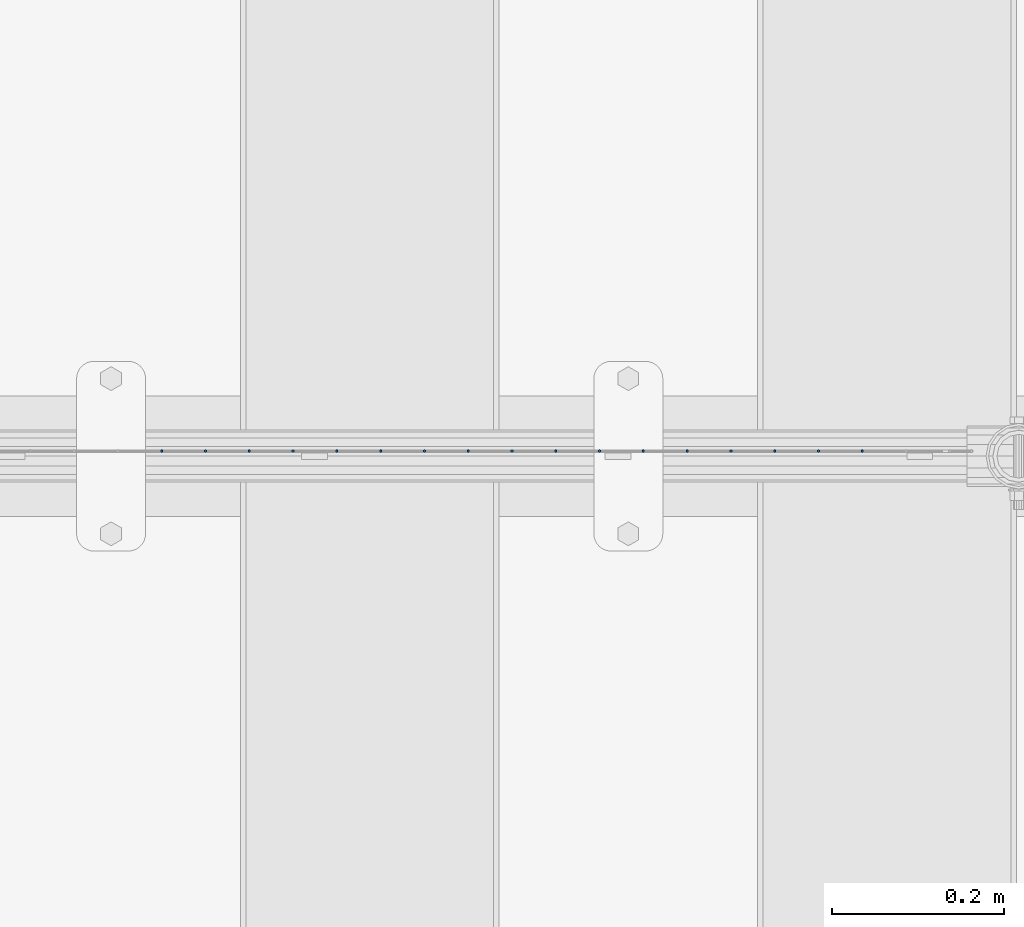
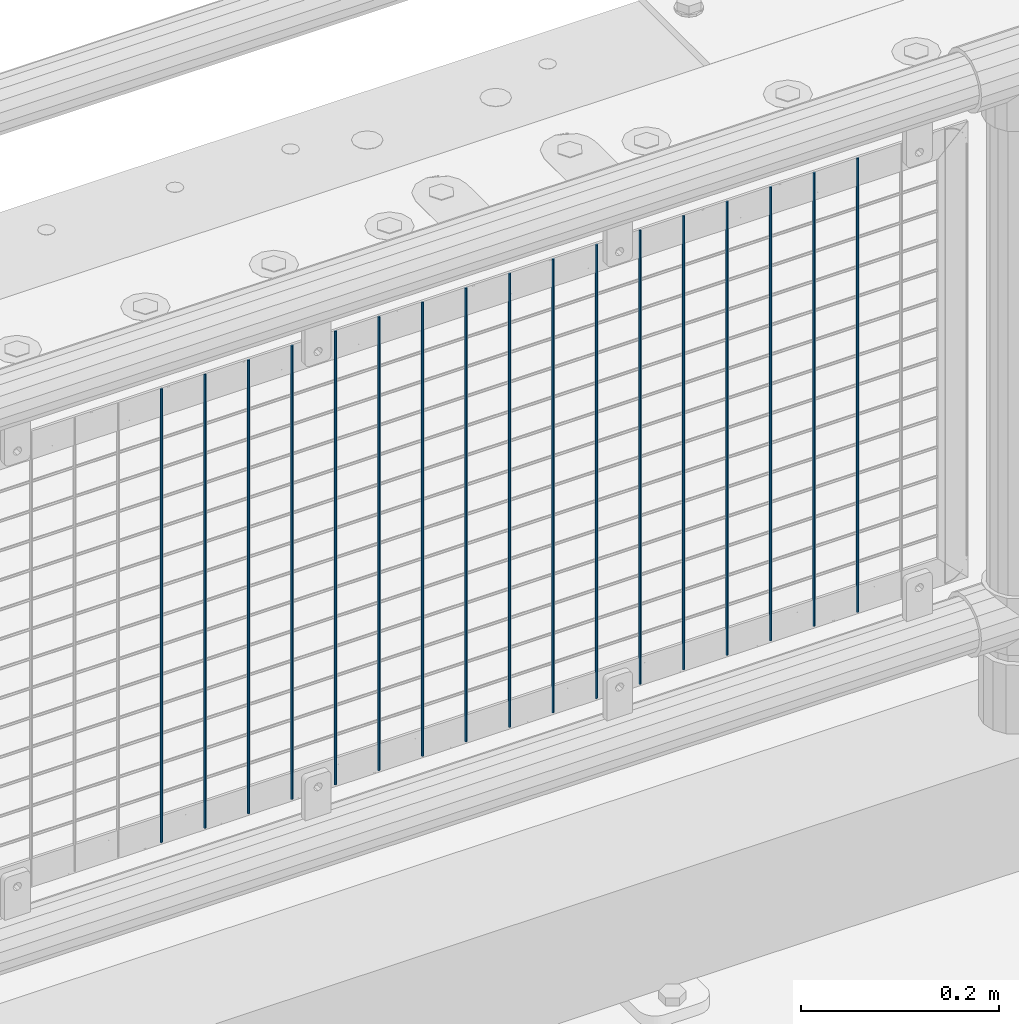
# One storey, part 74 of 242: 17 columns.
"""IFC2X3 building model written with IfcOpenShell, lengths in millimetres."""

from ifc_helpers import new_model, si_unit, frame, origin_with_axes, place, context, subcontext, project, spatial, faceted_brep, material, type_object, element, save


model = new_model("IFC2X3")

# Units and contexts
model_context = context("Model", 3, precision=1e-05, world=origin_with_axes())
body_context = subcontext(model_context, "Body", "Model", "MODEL_VIEW")
ifc_project = project(units=[si_unit("LENGTHUNIT", "METRE", prefix="MILLI"), si_unit("AREAUNIT", "SQUARE_METRE"), si_unit("VOLUMEUNIT", "CUBIC_METRE"), si_unit("MASSUNIT", "GRAM", prefix="KILO"), si_unit("TIMEUNIT", "SECOND"), si_unit("PLANEANGLEUNIT", "RADIAN"), si_unit("SOLIDANGLEUNIT", "STERADIAN"), si_unit("THERMODYNAMICTEMPERATUREUNIT", "DEGREE_CELSIUS"), si_unit("LUMINOUSINTENSITYUNIT", "LUMEN")], contexts=[model_context])

# Site, building, storey
site_placement = place(None, origin_with_axes())
site = spatial("IfcSite", under=ifc_project, at=site_placement, CompositionType="ELEMENT")
building_placement = place(site_placement, origin_with_axes())
building = spatial("IfcBuilding", under=site, at=building_placement, Name="Standard", CompositionType="ELEMENT")
storey_placement = place(building_placement, origin_with_axes())
storey = spatial("IfcBuildingStorey", under=building, at=storey_placement, Name="Undefined", CompositionType="ELEMENT", Elevation=0.0)

# Columns
ifc_material = material(Name="Misc_Undefined")
column_type = type_object("IfcColumnType", Name="D3", PredefinedType="NOTDEFINED")
for number, where, z_axis, x_axis in (
    (1, (-35478.589, -19329.5, 353.02), (-1.0, 0.0, 0.0), (0.0, 0.0, 1.0)),
    (2, (-35529.382, -19329.5, 353.02), (-1.0, 0.0, 0.0), (0.0, 0.0, 1.0)),
    (3, (-35580.175, -19329.5, 353.02), (-1.0, 0.0, 0.0), (0.0, 0.0, 1.0)),
    (4, (-35630.968, -19329.5, 353.02), (-1.0, 0.0, 0.0), (0.0, 0.0, 1.0)),
    (5, (-35681.761, -19329.5, 353.02), (-1.0, 0.0, 0.0), (0.0, 0.0, 1.0)),
    (6, (-35732.554, -19329.5, 353.02), (-1.0, 0.0, 0.0), (0.0, 0.0, 1.0)),
    (7, (-35783.347, -19329.5, 353.02), (-1.0, 0.0, 0.0), (0.0, 0.0, 1.0)),
    (8, (-35834.14, -19329.5, 353.02), (-1.0, 0.0, 0.0), (0.0, 0.0, 1.0)),
    (9, (-35884.933, -19329.5, 353.02), (-1.0, 0.0, 0.0), (0.0, 0.0, 1.0)),
    (10, (-35935.726, -19329.5, 353.02), (-1.0, 0.0, 0.0), (0.0, 0.0, 1.0)),
    (11, (-35986.519, -19329.5, 353.02), (-1.0, 0.0, 0.0), (0.0, 0.0, 1.0)),
    (12, (-36037.312, -19329.5, 353.02), (-1.0, 0.0, 0.0), (0.0, 0.0, 1.0)),
    (13, (-36088.105, -19329.5, 353.02), (-1.0, 0.0, 0.0), (0.0, 0.0, 1.0)),
    (14, (-36138.898, -19329.5, 353.02), (-1.0, 0.0, 0.0), (0.0, 0.0, 1.0)),
    (15, (-36189.691, -19329.5, 353.02), (-1.0, 0.0, 0.0), (0.0, 0.0, 1.0)),
    (16, (-36240.484, -19329.5, 353.02), (-1.0, 0.0, 0.0), (0.0, 0.0, 1.0)),
    (17, (-36291.277, -19329.5, 353.02), (-1.0, 0.0, 0.0), (0.0, 0.0, 1.0)),
):
    element("IfcColumn", number, at=place(storey_placement, frame(where, z_axis=z_axis, x_axis=x_axis)), inside=storey, type_object=column_type, material=ifc_material, ObjectType="D3", context=body_context, shape_type="Brep", body=[
        faceted_brep([(0.0, -1.50000000000364, 0.0), (-3.63797880709171e-12, -0.750000000003638, -1.29903810567669), (560.0, -0.75, -1.29903810567703), (560.0, -1.5, 0.0), (0.0, 0.749999999996362, -1.29903810567669), (560.0, 0.75, -1.29903810567703), (-3.63797880709171e-12, 1.49999999999636, 0.0), (560.0, 1.5, 0.0), (0.0, 0.749999999996362, 1.29903810567669), (560.0, 0.75, 1.29903810567703), (-3.63797880709171e-12, -0.750000000003638, 1.29903810567669), (560.0, -0.75, 1.29903810567703)], [[[0, 1, 2, 3]], [[1, 4, 5, 2]], [[4, 6, 7, 5]], [[6, 8, 9, 7]], [[8, 10, 11, 9]], [[10, 0, 3, 11]], [[5, 7, 9, 11, 3, 2]], [[10, 8, 6, 4, 1, 0]]]),
    ])

save(model, "model.ifc")
